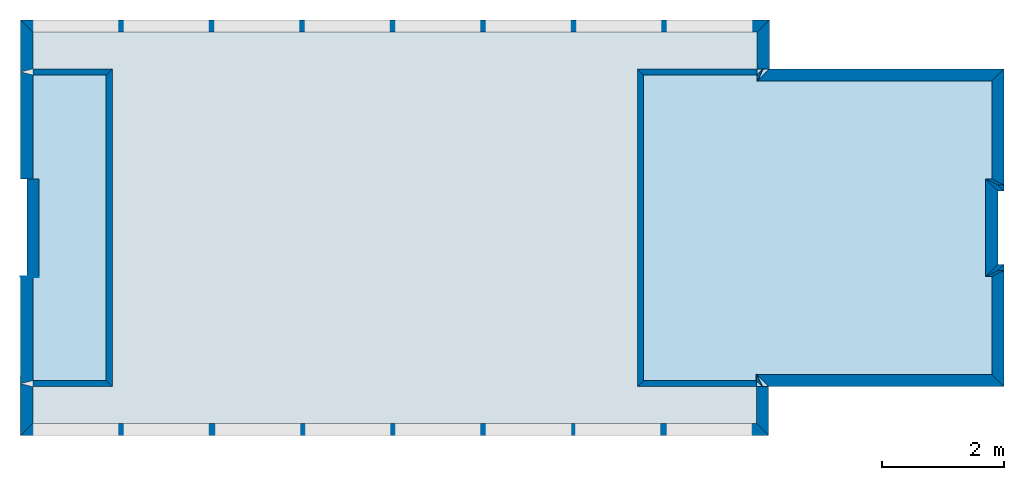
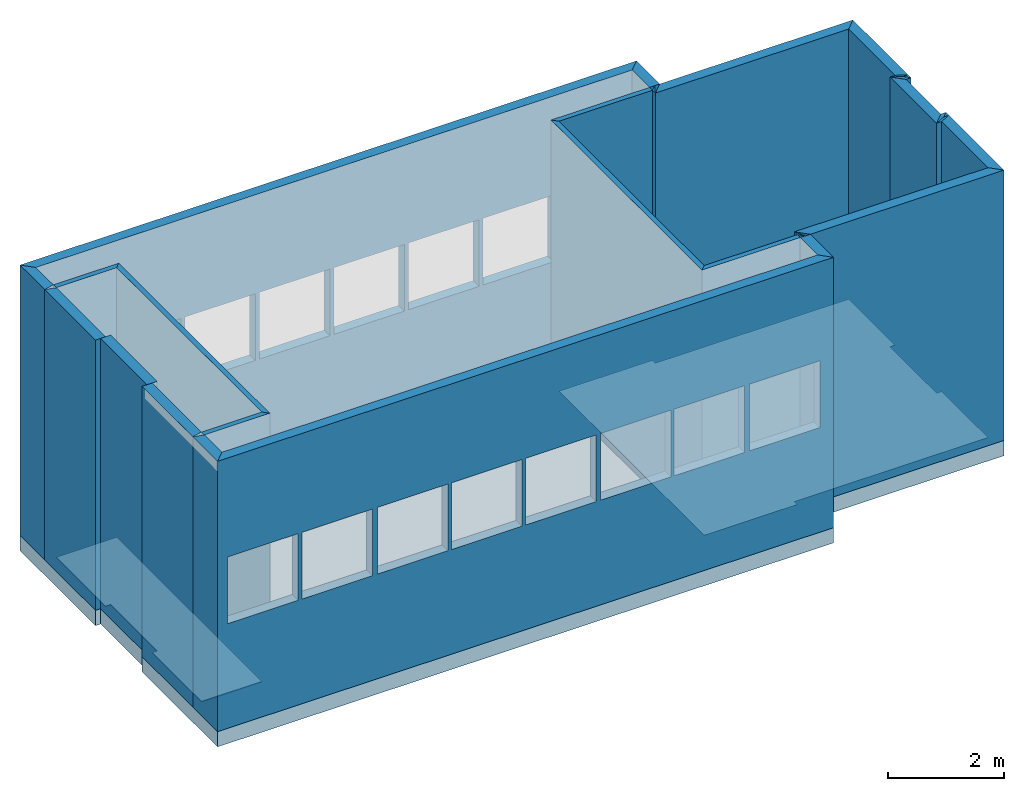
# One storey, part 1 of 18: 27 walls, 4 slabs, 16 openings.
"""IFC2X3 building model written with IfcOpenShell, lengths in metres."""

from ifc_helpers import new_model, entity, si_unit, converted_unit, derived_unit, frame, origin_with_axes, place, context, project, spatial, polyline, outline, extrude, material, layer, layer_set, layer_usage, element, save


model = new_model("IFC2X3")

# Units and contexts
context_of_model_1 = context(None, 3, world=origin_with_axes())
context_of_model_2 = context(None, 3, world=origin_with_axes())
context_of_model_3 = context(None, 2, world=origin_with_axes())
context_of_model_4 = context(None, 3, world=origin_with_axes())
ifc_project = project(units=[si_unit("LENGTHUNIT", "METRE"), si_unit("AREAUNIT", "SQUARE_METRE"), si_unit("ELECTRICCURRENTUNIT", "AMPERE"), si_unit("ELECTRICVOLTAGEUNIT", "VOLT"), si_unit("ELECTRICRESISTANCEUNIT", "OHM"), si_unit("POWERUNIT", "WATT"), si_unit("MASSUNIT", "GRAM"), si_unit("SOLIDANGLEUNIT", "STERADIAN"), si_unit("THERMODYNAMICTEMPERATUREUNIT", "KELVIN"), si_unit("PRESSUREUNIT", "PASCAL"), si_unit("LUMINOUSFLUXUNIT", "LUMEN"), si_unit("ILLUMINANCEUNIT", "LUX"), si_unit("FREQUENCYUNIT", "HERTZ"), si_unit("VOLUMEUNIT", "CUBIC_METRE"), si_unit("TIMEUNIT", "SECOND"), derived_unit("VOLUMETRICFLOWRATEUNIT", [(si_unit("TIMEUNIT", "SECOND"), -1), (si_unit("VOLUMEUNIT", "CUBIC_METRE"), 1)]), derived_unit("THERMALTRANSMITTANCEUNIT", [(si_unit("AREAUNIT", "SQUARE_METRE"), -1), (si_unit("THERMODYNAMICTEMPERATUREUNIT", "KELVIN"), -1), (si_unit("POWERUNIT", "WATT"), 1)]), converted_unit("PLANEANGLEUNIT", "DEGREE", entity("IfcPlaneAngleMeasure", 57.29577951308232), si_unit("PLANEANGLEUNIT", "RADIAN"), dimensions=[0, 0, 0, 0, 0, 0, 0])], contexts=[context_of_model_1, context_of_model_2, context_of_model_3, context_of_model_4])

# Site, building, storey
site = spatial("IfcSite", under=ifc_project, CompositionType="ELEMENT")
building_placement = place(None, origin_with_axes())
building = spatial("IfcBuilding", under=site, at=building_placement, Name="Tower", CompositionType="ELEMENT")
storey_placement = place(building_placement, frame((0.0, 0.0, 103.0), z_axis=(0.0, 0.0, 1.0), x_axis=(1.0, 0.0, 0.0)))
storey = spatial("IfcBuildingStorey", under=building, at=storey_placement, Name="Level 6", CompositionType="ELEMENT", Elevation=103.0)

# Slabs
ifc_material_1 = material()
ifc_layer_1 = layer(ifc_material_1, 0.3199999928474426, ventilated=False)
ifc_layer_set_1 = layer_set([ifc_layer_1])
ifc_layer_usage_1 = layer_usage(ifc_layer_set_1, "AXIS2", "POSITIVE", 0.0)
slab_1_placement = place(storey_placement, frame((0.1000000014901161, 1.399999976158142, 0.0), z_axis=(0.0, 0.0, 1.0), x_axis=(1.0, 0.0, 0.0)))
element("IfcSlab", 1, at=slab_1_placement, inside=storey, material=ifc_layer_usage_1, PredefinedType="FLOOR", context=context_of_model_1, shape_type="SweptSolid", body=[
    extrude(outline(polyline([(0.0, 0.0), (2.000000119209291, 0.0), (2.000000123679635, 0.0999999120831443), (3.199999932944773, 0.09999991089263416), (3.199999928474423, -1.430511357369829e-07), (5.200000405311582, -1.430511517241935e-07), (5.20000010013112, 3.839895351231112), (6.000000290865981, 3.839895315468318), (6.000001792110543, 16.088835068047), (3.400000456966503, 16.08883518427611), (3.399999975659022, 15.98883575648072), (1.800000786282108, 15.98883392065762), (1.800000790752515, 16.08883525580167), (-0.7999992926939846, 16.08883537203072), (-0.7999998398231419, 3.849762572348113), (1.720977860892539e-07, 3.849762536585327), (0.0, 0.0)])), frame((0.0, 0.0, 0.0), z_axis=(0.0, 0.0, 1.0), x_axis=(-4.470348091700783e-08, 0.9999999999999991, 0.0)), (0.0, 0.0, -1.0), 0.3199999928474426),
])
slab_2_placement = place(storey_placement, frame((-3.939895868301392, 6.600000381469727, 0.0), z_axis=(0.0, 0.0, 1.0), x_axis=(1.0, 0.0, 0.0)))
element("IfcSlab", 2, at=slab_2_placement, inside=storey, material=ifc_layer_usage_1, PredefinedType="FLOOR", context=context_of_model_1, shape_type="SweptSolid", body=[
    extrude(outline(polyline([(0.0, 0.0), (0.5999999046326159, 0.0), (0.5999961499604943, 11.84893989562933), (-4.708346343258583e-06, 11.84893965721037), (-4.191772597306827e-06, 10.54893946647561), (-5.200004597083773, 10.54893740018077), (-5.200005113657518, 11.84893759091553), (-5.800005137499329, 11.8489373524969), (-5.800000433073572, 0.009864171345491014), (-5.200000409231761, 0.009864409764117486), (-5.20000106497745, 1.960102160771091), (-7.788755649789618e-07, 1.960104227065886), (0.0, 0.0)])), frame((0.0, 0.0, 0.0), z_axis=(0.0, 0.0, 1.0), x_axis=(3.973643616619371e-07, 0.999999999999921, 0.0)), (0.0, 0.0, 1.0), 0.009999999776482582),
])
slab_3_placement = place(storey_placement, frame((-0.1000000089406967, 1.600000023841858, 0.0), z_axis=(0.0, 0.0, 1.0), x_axis=(1.0, 0.0, 0.0)))
element("IfcSlab", 3, at=slab_3_placement, inside=storey, material=ifc_layer_usage_1, PredefinedType="FLOOR", context=context_of_model_1, shape_type="SweptSolid", body=[
    extrude(outline(polyline([(0.0, 0.0), (1.60000002384186, -1.323488980084844e-23), (1.600000028498468, 0.09999990463256826), (3.19999969471246, 0.09999991953374611), (3.199999690055844, -1.490115952851313e-07), (4.80000054836273, -1.490116341429366e-07), (4.80000025033464, 3.839895397424694), (4.900000631804367, 3.839895392768063), (4.900000718422233, 5.699999953620113), (-0.09999963920562997, 5.70000018645077), (-0.09999984457333197, 3.849762340076265), (1.792685258227271e-07, 3.849762335419651), (0.0, 0.0)])), frame((0.0, 0.0, 0.0), z_axis=(0.0, 0.0, 1.0), x_axis=(-4.65661280368845e-08, 0.999999999999999, 0.0)), (0.0, 0.0, 1.0), 0.009999999776482582),
])
slab_4_placement = place(storey_placement, frame((-15.7888355255127, 6.500000476837158, 0.0), z_axis=(0.0, 0.0, 1.0), x_axis=(1.0, 0.0, 0.0)))
element("IfcSlab", 4, at=slab_4_placement, inside=storey, material=ifc_layer_usage_1, PredefinedType="FLOOR", context=context_of_model_1, shape_type="SweptSolid", body=[
    extrude(outline(polyline([(0.0, 0.0), (1.700000762939453, 0.0), (1.700001239776611, 0.1000003814697266), (3.305324554443359, 0.09904003143310547), (3.30534553527832, -0.001138687133789063), (5.000000357627869, 0.0), (5.000000476837158, 1.199999809265137), (0.0, 1.199999809265137), (0.0, 0.0)])), frame((0.0, 0.0, 0.0), z_axis=(0.0, 0.0, 1.0), x_axis=(0.0, -1.0, 0.0)), (0.0, 0.0, 1.0), 0.01999999955296516),
])

# Walls
ifc_material_2 = material(Name="Layer-Yttervegg 20.0cm")
ifc_layer_2 = layer(ifc_material_2, 0.2000000029802322, ventilated=False)
ifc_layer_set_2 = layer_set([ifc_layer_2], Name="ML-Yttervegg 20.0cm - 0.200")
ifc_layer_usage_2 = layer_usage(ifc_layer_set_2, "AXIS2", "POSITIVE", 0.0)
wall_1_placement = place(storey_placement, frame((0.09999991208314896, 3.400000095367432, 0.0), z_axis=(0.0, 0.0, 1.0), x_axis=(-1.0, -8.742277657347586e-08, 0.0)))
element("IfcWallStandardCase", 5, at=wall_1_placement, inside=storey, material=ifc_layer_usage_2, Name="Yttervegg 20.0cm", context=context_of_model_1, shape_type="SweptSolid", body=[
    extrude(outline(polyline([(0.0, 0.0), (0.0999999120831444, 0.0), (0.2999999299645421, 0.2000000476837162), (0.1999999880790708, 0.2000000476837158), (0.0, 0.0)])), frame((0.0, 0.0, 0.0), z_axis=(0.0, 0.0, 1.0), x_axis=(0.9999999999999961, -8.742278149038443e-08, 0.0)), (0.0, 0.0, 1.0), 5.680000007152557),
])
wall_2_placement = place(storey_placement, frame((-5.245365386485901e-08, 4.599999904632568, 0.0), z_axis=(0.0, 0.0, 1.0), x_axis=(1.0, 0.0, 0.0)))
element("IfcWallStandardCase", 6, at=wall_2_placement, inside=storey, material=ifc_layer_usage_2, Name="Yttervegg 20.0cm", context=context_of_model_1, shape_type="SweptSolid", body=[
    extrude(outline(polyline([(0.0, 0.0), (0.10000005394377, 0.0), (-0.09999995648704285, 0.1999998092651367), (-0.2000000250323843, 0.1999998092651367), (0.0, 0.0)])), origin_with_axes(), (0.0, 0.0, 1.0), 5.680000007152557),
])
wall_3_placement = place(storey_placement, frame((-3.739895582199097, 6.599999904632568, 0.0), z_axis=(0.0, 0.0, 1.0), x_axis=(-4.371138828673793e-08, 1.0, 0.0)))
element("IfcWallStandardCase", 7, at=wall_3_placement, inside=storey, material=ifc_layer_usage_2, Name="Yttervegg 20.0cm", context=context_of_model_1, shape_type="SweptSolid", body=[
    extrude(outline(polyline([(0.0, 0.0), (0.8000001907348633, 0.0), (0.600000381469726, 0.2000000476837155), (4.768371582176146e-07, 0.2000002861022946), (0.0, 0.0)])), frame((0.0, 0.0, 0.0), z_axis=(0.0, 0.0, 1.0), x_axis=(0.999999999999999, -4.371138963349459e-08, 0.0)), (0.0, 0.0, 1.0), 5.680000007152557),
])

# Wall, openings
ifc_material_3 = material()
ifc_layer_3 = layer(ifc_material_3, 0.2, ventilated=False)
ifc_layer_set_3 = layer_set([ifc_layer_3])
ifc_layer_usage_3 = layer_usage(ifc_layer_set_3, "AXIS2", "POSITIVE", 0.0)
wall_4_placement = place(storey_placement, frame((-3.739895582199097, 7.400000095367432, 0.0), z_axis=(0.0, 0.0, 1.0), x_axis=(-1.0, 1.509958025280866e-07, 0.0)))
wall_4 = element("IfcWallStandardCase", 8, at=wall_4_placement, inside=storey, material=ifc_layer_usage_3, context=context_of_model_1, shape_type="SweptSolid", body=[
    extrude(outline(polyline([(0.0, 0.0), (12.24893975257877, -1.058791184067875e-22), (12.04893992774211, 0.1999997936936115), (0.2000000321121897, 0.1999998248366815), (0.0, 0.0)])), frame((0.0, 0.0, 0.0), z_axis=(0.0, 0.0, 1.0), x_axis=(0.9999999999999973, 7.313809583869059e-08, 0.0)), (0.0, 0.0, 1.0), 5.680000007152557),
])
opening_1_placement = place(wall_4_placement, frame((10.64894029458421, 0.2000004635360728, 2.2), z_axis=(0.0, 0.0, 1.0), x_axis=(1.0, 0.0, 0.0)))
element("IfcOpeningElement", 9, at=opening_1_placement, cuts=wall_4, context=context_of_model_1, shape_type="SweptSolid", body=[
    extrude(outline(polyline([(0.0, 0.0), (1.399999976158142, 0.0), (1.399999976158142, 1.39999961853027), (0.0, 1.39999961853027), (0.0, 0.0)])), frame((0.0, 0.0, 0.0), z_axis=(1.153203098282065e-07, 0.9999999999999933, 0.0), x_axis=(0.0, 0.0, 1.0)), (0.0, 1.153203098282065e-07, -0.9999999999999933), 0.2),
])
opening_2_placement = place(wall_4_placement, frame((9.167823046049076, 0.2000002398935905, 2.2), z_axis=(0.0, 0.0, 1.0), x_axis=(1.0, 0.0, 0.0)))
element("IfcOpeningElement", 10, at=opening_2_placement, cuts=wall_4, context=context_of_model_1, shape_type="SweptSolid", body=[
    extrude(outline(polyline([(0.0, 0.0), (1.399999976158142, 0.0), (1.399999976158142, 1.399999618530248), (0.0, 1.399999618530248), (0.0, 0.0)])), frame((0.0, 0.0, 0.0), z_axis=(1.153203104626217e-07, 0.9999999999999934, 0.0), x_axis=(0.0, 0.0, 1.0)), (0.0, 1.153203104626217e-07, -0.9999999999999933), 0.2),
])
opening_3_placement = place(wall_4_placement, frame((7.686705797513865, 0.2000004930882655, 2.2), z_axis=(0.0, 0.0, 1.0), x_axis=(1.0, 0.0, 0.0)))
element("IfcOpeningElement", 11, at=opening_3_placement, cuts=wall_4, context=context_of_model_1, shape_type="SweptSolid", body=[
    extrude(outline(polyline([(0.0, 0.0), (1.399999976158142, 0.0), (1.399999976158142, 1.399999618530224), (0.0, 1.399999618530224), (0.0, 0.0)])), frame((0.0, 0.0, 0.0), z_axis=(1.153203098282103e-07, 0.9999999999999933, 0.0), x_axis=(0.0, 0.0, 1.0)), (0.0, 1.153203098282103e-07, -0.9999999999999933), 0.2),
])
opening_4_placement = place(wall_4_placement, frame((6.20558759530441, 0.2000002694456393, 2.2), z_axis=(0.0, 0.0, 1.0), x_axis=(1.0, 0.0, 0.0)))
element("IfcOpeningElement", 12, at=opening_4_placement, cuts=wall_4, context=context_of_model_1, shape_type="SweptSolid", body=[
    extrude(outline(polyline([(0.0, 0.0), (1.399999976158142, 0.0), (1.399999976158142, 1.3999996185302), (0.0, 1.3999996185302), (0.0, 0.0)])), frame((0.0, 0.0, 0.0), z_axis=(1.153203098282124e-07, 0.9999999999999934, 0.0), x_axis=(0.0, 0.0, 1.0)), (0.0, 1.153203098282124e-07, -0.9999999999999933), 0.2),
])
opening_5_placement = place(wall_4_placement, frame((4.724470346769271, 0.200000045803157, 2.2), z_axis=(0.0, 0.0, 1.0), x_axis=(1.0, 0.0, 0.0)))
element("IfcOpeningElement", 13, at=opening_5_placement, cuts=wall_4, context=context_of_model_1, shape_type="SweptSolid", body=[
    extrude(outline(polyline([(0.0, 0.0), (1.399999976158142, 0.0), (1.399999976158142, 1.399999618530173), (0.0, 1.399999618530173), (0.0, 0.0)])), frame((0.0, 0.0, 0.0), z_axis=(1.153203098282146e-07, 0.9999999999999933, 0.0), x_axis=(0.0, 0.0, 1.0)), (0.0, 1.153203098282146e-07, -0.9999999999999933), 0.2),
])
opening_6_placement = place(wall_4_placement, frame((3.243353098234131, 0.1999998221606747, 2.2), z_axis=(0.0, 0.0, 1.0), x_axis=(1.0, 0.0, 0.0)))
element("IfcOpeningElement", 14, at=opening_6_placement, cuts=wall_4, context=context_of_model_1, shape_type="SweptSolid", body=[
    extrude(outline(polyline([(0.0, 0.0), (1.399999976158142, 0.0), (1.399999976158142, 1.399999618530151), (0.0, 1.399999618530151), (0.0, 0.0)])), frame((0.0, 0.0, 0.0), z_axis=(1.153203104626297e-07, 0.9999999999999933, 0.0), x_axis=(0.0, 0.0, 1.0)), (0.0, 1.153203104626297e-07, -0.9999999999999933), 0.2),
])
opening_7_placement = place(wall_4_placement, frame((1.762234896024604, 0.2000000753552058, 2.2), z_axis=(0.0, 0.0, 1.0), x_axis=(1.0, 0.0, 0.0)))
element("IfcOpeningElement", 15, at=opening_7_placement, cuts=wall_4, context=context_of_model_1, shape_type="SweptSolid", body=[
    extrude(outline(polyline([(0.0, 0.0), (1.399999976158142, 0.0), (1.399999976158142, 1.399999618530126), (0.0, 1.399999618530126), (0.0, 0.0)])), frame((0.0, 0.0, 0.0), z_axis=(1.153203098282184e-07, 0.9999999999999933, 0.0), x_axis=(0.0, 0.0, 1.0)), (0.0, 1.153203098282184e-07, -0.9999999999999933), 0.2),
])
opening_8_placement = place(wall_4_placement, frame((0.2783190902079702, 0.1999998512901531, 2.2), z_axis=(0.0, 0.0, 1.0), x_axis=(1.0, 0.0, 0.0)))
element("IfcOpeningElement", 16, at=opening_8_placement, cuts=wall_4, context=context_of_model_1, shape_type="SweptSolid", body=[
    extrude(outline(polyline([(0.0, 0.0), (1.399999976158142, 0.0), (1.399999976158142, 1.399999618530102), (0.0, 1.399999618530102), (0.0, 0.0)])), frame((0.0, 0.0, 0.0), z_axis=(1.153203098282204e-07, 0.9999999999999933, 0.0), x_axis=(0.0, 0.0, 1.0)), (0.0, 1.153203098282204e-07, -0.9999999999999933), 0.2),
])

# Walls
ifc_material_4 = material()
ifc_layer_4 = layer(ifc_material_4, 0.2, ventilated=False)
ifc_layer_set_4 = layer_set([ifc_layer_4])
ifc_layer_usage_4 = layer_usage(ifc_layer_set_4, "AXIS2", "POSITIVE", 0.0)
wall_5_placement = place(storey_placement, frame((-15.98883533477783, 7.400001049041748, 0.0), z_axis=(0.0, 0.0, 1.0), x_axis=(-4.371138828673793e-08, -1.0, 0.0)))
element("IfcWallStandardCase", 17, at=wall_5_placement, inside=storey, material=ifc_layer_usage_4, context=context_of_model_1, shape_type="SweptSolid", body=[
    extrude(outline(polyline([(0.0, 0.0), (0.8500008583068847, 0.0), (0.8000006675720213, 0.1999998092651369), (0.1999998092651368, 0.1999998092651379), (0.0, 0.0)])), frame((0.0, 0.0, 0.0), z_axis=(0.0, 0.0, 1.0), x_axis=(0.9999999999999991, 4.371139137835724e-08, 0.0)), (0.0, 0.0, 1.0), 5.680000007152557),
])
ifc_material_5 = material()
ifc_layer_5 = layer(ifc_material_5, 0.1, ventilated=False)
ifc_layer_set_5 = layer_set([ifc_layer_5])
ifc_layer_usage_5 = layer_usage(ifc_layer_set_5, "AXIS2", "POSITIVE", 0.0)
wall_6_placement = place(storey_placement, frame((-15.7888355255127, 6.500000476837158, 0.0), z_axis=(0.0, 0.0, 1.0), x_axis=(1.0, 0.0, 0.0)))
element("IfcWallStandardCase", 18, at=wall_6_placement, inside=storey, material=ifc_layer_usage_5, context=context_of_model_1, shape_type="SweptSolid", body=[
    extrude(outline(polyline([(0.0, 0.0), (1.199999809265137, 0.0), (1.300000190734863, 0.09999990463256836), (0.0, 0.09999990463256836), (0.0, 0.0)])), origin_with_axes(), (0.0, 0.0, 1.0), 5.680000007152557),
])
wall_7_placement = place(storey_placement, frame((-14.58883571624756, 6.500000476837158, 0.0), z_axis=(0.0, 0.0, 1.0), x_axis=(-4.371138828673793e-08, -1.0, 0.0)))
element("IfcWallStandardCase", 19, at=wall_7_placement, inside=storey, material=ifc_layer_usage_5, context=context_of_model_1, shape_type="SweptSolid", body=[
    extrude(outline(polyline([(0.0, 0.0), (5.000000476837157, 0.0), (5.100000500679015, 0.1000003814697265), (-0.09999990463256864, 0.1000003814697269), (0.0, 0.0)])), frame((0.0, 0.0, 0.0), z_axis=(0.0, 0.0, 1.0), x_axis=(0.9999999999999991, 4.371139015770818e-08, 0.0)), (0.0, 0.0, 1.0), 5.680000007152557),
])
wall_8_placement = place(storey_placement, frame((-14.58883571624756, 1.5, 0.0), z_axis=(0.0, 0.0, 1.0), x_axis=(-1.0, 1.509958025280866e-07, 0.0)))
element("IfcWallStandardCase", 20, at=wall_8_placement, inside=storey, material=ifc_layer_usage_5, context=context_of_model_1, shape_type="SweptSolid", body=[
    extrude(outline(polyline([(0.0, 0.0), (1.199999809265142, 0.0), (1.199999799331019, 0.100000143051147), (-0.1000003914038372, 0.1000000139077105), (0.0, 0.0)])), frame((0.0, 0.0, 0.0), z_axis=(0.0, 0.0, 1.0), x_axis=(0.9999999999999987, 5.165470854219175e-08, 0.0)), (0.0, 0.0, 1.0), 5.680000007152557),
])
ifc_material_6 = material()
ifc_layer_6 = layer(ifc_material_6, 0.2, ventilated=False)
ifc_layer_set_6 = layer_set([ifc_layer_6])
ifc_layer_usage_6 = layer_usage(ifc_layer_set_6, "AXIS2", "POSITIVE", 0.0)
wall_9_placement = place(storey_placement, frame((-15.98883533477783, 1.450000047683716, 0.0), z_axis=(0.0, 0.0, 1.0), x_axis=(-4.371138828673793e-08, -1.0, 0.0)))
element("IfcWallStandardCase", 21, at=wall_9_placement, inside=storey, material=ifc_layer_usage_6, context=context_of_model_1, shape_type="SweptSolid", body=[
    extrude(outline(polyline([(0.0, 0.0), (0.8500000834465025, 0.0), (0.6500000953674314, 0.1999998092651363), (0.05000007152557353, 0.1999998092651369), (0.0, 0.0)])), frame((0.0, 0.0, 0.0), z_axis=(0.0, 0.0, 1.0), x_axis=(0.9999999999999991, 4.371138942904995e-08, 0.0)), (0.0, 0.0, 1.0), 5.680000007152557),
])

# Wall, openings
ifc_material_7 = material()
ifc_layer_7 = layer(ifc_material_7, 0.2, ventilated=False)
ifc_layer_set_7 = layer_set([ifc_layer_7])
ifc_layer_usage_7 = layer_usage(ifc_layer_set_7, "AXIS2", "POSITIVE", 0.0)
wall_10_placement = place(storey_placement, frame((-15.98883533477783, 0.5999999642372131, 0.0), z_axis=(0.0, 0.0, 1.0), x_axis=(1.0, 0.0, 0.0)))
wall_10 = element("IfcWallStandardCase", 22, at=wall_10_placement, inside=storey, material=ifc_layer_usage_7, context=context_of_model_1, shape_type="SweptSolid", body=[
    extrude(outline(polyline([(0.0, 0.0), (12.23907279968262, 0.0), (12.03907299041748, 0.199999988079071), (0.1999998092651367, 0.199999988079071), (0.0, 0.0)])), origin_with_axes(), (0.0, 0.0, 1.0), 5.680000007152557),
])
opening_9_placement = place(wall_10_placement, frame((0.1999998092651367, 0.199999988079071, 2.2), z_axis=(0.0, 0.0, 1.0), x_axis=(1.0, 0.0, 0.0)))
element("IfcOpeningElement", 23, at=opening_9_placement, cuts=wall_10, context=context_of_model_1, shape_type="SweptSolid", body=[
    extrude(outline(polyline([(0.0, 0.0), (1.399999976158142, 0.0), (1.399999976158142, 1.399999618530103), (0.0, 1.399999618530103), (0.0, 0.0)])), frame((0.0, 0.0, 0.0), z_axis=(0.0, 1.0, 0.0), x_axis=(0.0, 0.0, 1.0)), (0.0, 0.0, -1.0), 0.2),
])
opening_10_placement = place(wall_10_placement, frame((1.679572105407715, 0.199999988079071, 2.2), z_axis=(0.0, 0.0, 1.0), x_axis=(1.0, 0.0, 0.0)))
element("IfcOpeningElement", 24, at=opening_10_placement, cuts=wall_10, context=context_of_model_1, shape_type="SweptSolid", body=[
    extrude(outline(polyline([(0.0, 0.0), (1.399999976158142, 0.0), (1.399999976158142, 1.399999618530103), (0.0, 1.399999618530103), (0.0, 0.0)])), frame((0.0, 0.0, 0.0), z_axis=(0.0, 1.0, 0.0), x_axis=(0.0, 0.0, 1.0)), (0.0, 0.0, -1.0), 0.2),
])
opening_11_placement = place(wall_10_placement, frame((3.175571441650391, 0.199999988079071, 2.2), z_axis=(0.0, 0.0, 1.0), x_axis=(1.0, 0.0, 0.0)))
element("IfcOpeningElement", 25, at=opening_11_placement, cuts=wall_10, context=context_of_model_1, shape_type="SweptSolid", body=[
    extrude(outline(polyline([(0.0, 0.0), (1.399999976158142, 0.0), (1.399999976158142, 1.399999618530103), (0.0, 1.399999618530103), (0.0, 0.0)])), frame((0.0, 0.0, 0.0), z_axis=(0.0, 1.0, 0.0), x_axis=(0.0, 0.0, 1.0)), (0.0, 0.0, -1.0), 0.2),
])
opening_12_placement = place(wall_10_placement, frame((4.649572372436523, 0.199999988079071, 2.2), z_axis=(0.0, 0.0, 1.0), x_axis=(1.0, 0.0, 0.0)))
element("IfcOpeningElement", 26, at=opening_12_placement, cuts=wall_10, context=context_of_model_1, shape_type="SweptSolid", body=[
    extrude(outline(polyline([(0.0, 0.0), (1.399999976158142, 0.0), (1.399999976158142, 1.399999618530103), (0.0, 1.399999618530103), (0.0, 0.0)])), frame((0.0, 0.0, 0.0), z_axis=(0.0, 1.0, 0.0), x_axis=(0.0, 0.0, 1.0)), (0.0, 0.0, -1.0), 0.2),
])
opening_13_placement = place(wall_10_placement, frame((6.123573303222656, 0.199999988079071, 2.2), z_axis=(0.0, 0.0, 1.0), x_axis=(1.0, 0.0, 0.0)))
element("IfcOpeningElement", 27, at=opening_13_placement, cuts=wall_10, context=context_of_model_1, shape_type="SweptSolid", body=[
    extrude(outline(polyline([(0.0, 0.0), (1.399999976158142, 0.0), (1.399999976158142, 1.399999618530103), (0.0, 1.399999618530103), (0.0, 0.0)])), frame((0.0, 0.0, 0.0), z_axis=(0.0, 1.0, 0.0), x_axis=(0.0, 0.0, 1.0)), (0.0, 0.0, -1.0), 0.2),
])
opening_14_placement = place(wall_10_placement, frame((7.608574867248535, 0.199999988079071, 2.2), z_axis=(0.0, 0.0, 1.0), x_axis=(1.0, 0.0, 0.0)))
element("IfcOpeningElement", 28, at=opening_14_placement, cuts=wall_10, context=context_of_model_1, shape_type="SweptSolid", body=[
    extrude(outline(polyline([(0.0, 0.0), (1.399999976158142, 0.0), (1.399999976158142, 1.399999618530103), (0.0, 1.399999618530103), (0.0, 0.0)])), frame((0.0, 0.0, 0.0), z_axis=(0.0, 1.0, 0.0), x_axis=(0.0, 0.0, 1.0)), (0.0, 0.0, -1.0), 0.2),
])
opening_15_placement = place(wall_10_placement, frame((9.071574211120605, 0.199999988079071, 2.2), z_axis=(0.0, 0.0, 1.0), x_axis=(1.0, 0.0, 0.0)))
element("IfcOpeningElement", 29, at=opening_15_placement, cuts=wall_10, context=context_of_model_1, shape_type="SweptSolid", body=[
    extrude(outline(polyline([(0.0, 0.0), (1.399999976158142, 0.0), (1.399999976158142, 1.399999618530103), (0.0, 1.399999618530103), (0.0, 0.0)])), frame((0.0, 0.0, 0.0), z_axis=(0.0, 1.0, 0.0), x_axis=(0.0, 0.0, 1.0)), (0.0, 0.0, -1.0), 0.2),
])
opening_16_placement = place(wall_10_placement, frame((10.56757545471191, 0.199999988079071, 2.2), z_axis=(0.0, 0.0, 1.0), x_axis=(1.0, 0.0, 0.0)))
element("IfcOpeningElement", 30, at=opening_16_placement, cuts=wall_10, context=context_of_model_1, shape_type="SweptSolid", body=[
    extrude(outline(polyline([(0.0, 0.0), (1.399999976158142, 0.0), (1.399999976158142, 1.399999618530103), (0.0, 1.399999618530103), (0.0, 0.0)])), frame((0.0, 0.0, 0.0), z_axis=(0.0, 1.0, 0.0), x_axis=(0.0, 0.0, 1.0)), (0.0, 0.0, -1.0), 0.2),
])

# Walls
wall_11_placement = place(storey_placement, frame((-3.749762535095215, 0.5999999642372131, 0.0), z_axis=(0.0, 0.0, 1.0), x_axis=(-4.371138828673793e-08, 1.0, 0.0)))
element("IfcWallStandardCase", 31, at=wall_11_placement, inside=storey, material=ifc_layer_usage_2, Name="Yttervegg 20.0cm", context=context_of_model_1, shape_type="SweptSolid", body=[
    extrude(outline(polyline([(0.0, 0.0), (0.8000000119209291, -6.617444900424221e-24), (0.800000011920929, 0.1999998092651365), (0.1999999880790711, 0.1999998092651364), (0.0, 0.0)])), frame((0.0, 0.0, 0.0), z_axis=(0.0, 0.0, 1.0), x_axis=(0.999999999999999, -4.371138996685581e-08, 0.0)), (0.0, 0.0, 1.0), 5.680000007152557),
])
wall_12_placement = place(storey_placement, frame((-3.949762344360352, 1.5, 0.0), z_axis=(0.0, 0.0, 1.0), x_axis=(-1.0, 1.509958025280866e-07, 0.0)))
element("IfcWallStandardCase", 32, at=wall_12_placement, inside=storey, material=ifc_layer_usage_5, context=context_of_model_1, shape_type="SweptSolid", body=[
    extrude(outline(polyline([(0.0, 0.0), (1.850237846374515, 0.0), (1.950237744564166, 0.1000000302847687), (-6.442918429059665e-09, 0.1000000238418577), (0.0, 0.0)])), frame((0.0, 0.0, 0.0), z_axis=(0.0, 0.0, 1.0), x_axis=(0.9999999999999962, 8.656662868464251e-08, 0.0)), (0.0, 0.0, 1.0), 5.680000007152557),
])
wall_13_placement = place(storey_placement, frame((-5.800000190734863, 1.50000011920929, 0.0), z_axis=(0.0, 0.0, 1.0), x_axis=(-4.371138828673793e-08, 1.0, 0.0)))
element("IfcWallStandardCase", 33, at=wall_13_placement, inside=storey, material=ifc_layer_usage_5, context=context_of_model_1, shape_type="SweptSolid", body=[
    extrude(outline(polyline([(0.0, 0.0), (5.000000357627869, 0.0), (5.100000262260437, 0.0999999046325687), (-0.1000000238418578, 0.09999990463256829), (0.0, 0.0)])), frame((0.0, 0.0, 0.0), z_axis=(0.0, 0.0, 1.0), x_axis=(0.9999999999999991, -4.371138995641915e-08, 0.0)), (0.0, 0.0, 1.0), 5.680000007152557),
])
wall_14_placement = place(storey_placement, frame((-5.800000190734863, 6.500000476837158, 0.0), z_axis=(0.0, 0.0, 1.0), x_axis=(1.0, 0.0, 0.0)))
element("IfcWallStandardCase", 34, at=wall_14_placement, inside=storey, material=ifc_layer_usage_5, context=context_of_model_1, shape_type="SweptSolid", body=[
    extrude(outline(polyline([(0.0, 0.0), (1.860104560852051, 0.0), (1.860104322433472, 0.09999990463256836), (-0.09999990463256836, 0.09999990463256836), (0.0, 0.0)])), origin_with_axes(), (0.0, 0.0, 1.0), 5.680000007152557),
])
wall_15_placement = place(storey_placement, frame((0.1000000014901161, 1.399999976158142, 0.0), z_axis=(0.0, 0.0, 1.0), x_axis=(-4.371138828673793e-08, 1.0, 0.0)))
element("IfcWallStandardCase", 35, at=wall_15_placement, inside=storey, material=ifc_layer_usage_2, Name="Yttervegg 20.0cm", context=context_of_model_1, shape_type="SweptSolid", body=[
    extrude(outline(polyline([(0.0, 0.0), (2.000000119209291, 0.0), (1.800000080466272, 0.2000000044703497), (0.2000000566244123, 0.2000000014901143), (0.0, 0.0)])), frame((0.0, 0.0, 0.0), z_axis=(0.0, 0.0, 1.0), x_axis=(1.0, 9.92090919679804e-10, 0.0)), (0.0, 0.0, 1.0), 5.680000007152557),
])
wall_16_placement = place(storey_placement, frame((0.09999991953372955, 3.299999952316284, 0.0), z_axis=(0.0, 0.0, 1.0), x_axis=(-1.0, -8.742277657347586e-08, 0.0)))
element("IfcWallStandardCase", 36, at=wall_16_placement, inside=storey, material=ifc_layer_usage_5, context=context_of_model_1, shape_type="SweptSolid", body=[
    extrude(outline(polyline([(0.0, 0.0), (0.09999991208314898, 0.0), (0.2999999076128005, 0.09999990463256865), (0.2000000029802322, 0.09999990463256886), (0.0, 0.0)])), frame((0.0, 0.0, 0.0), z_axis=(0.0, 0.0, 1.0), x_axis=(0.9999999999999961, -8.742278149038043e-08, 0.0)), (0.0, 0.0, 1.0), 5.680000007152557),
])
wall_17_placement = place(storey_placement, frame((4.579669976578771e-15, 3.400000095367432, 0.0), z_axis=(0.0, 0.0, 1.0), x_axis=(-4.371138828673793e-08, 1.0, 0.0)))
element("IfcWallStandardCase", 37, at=wall_17_placement, inside=storey, material=ifc_layer_usage_2, Name="Yttervegg 20.0cm", context=context_of_model_1, shape_type="SweptSolid", body=[
    extrude(outline(polyline([(0.0, 0.0), (1.199999809265139, 0.0), (1.399999627272554, 0.2000000162901147), (-0.200000038941438, 0.1999999968213553), (0.0, 0.0)])), frame((0.0, 0.0, 0.0), z_axis=(0.0, 0.0, 1.0), x_axis=(1.0, -1.01701678366724e-15, 0.0)), (0.0, 0.0, 1.0), 5.680000007152557),
])
wall_18_placement = place(storey_placement, frame((-7.450580596923828e-08, 4.699999809265137, 0.0), z_axis=(0.0, 0.0, 1.0), x_axis=(1.0, 0.0, 0.0)))
element("IfcWallStandardCase", 38, at=wall_18_placement, inside=storey, material=ifc_layer_usage_5, context=context_of_model_1, shape_type="SweptSolid", body=[
    extrude(outline(polyline([(0.0, 0.0), (0.1000000685453415, 0.0), (-0.09999993443489075, 0.09999990463256836), (-0.2000000029802322, 0.09999990463256836), (0.0, 0.0)])), origin_with_axes(), (0.0, 0.0, 1.0), 5.680000007152557),
])
wall_19_placement = place(storey_placement, frame((0.1000000014901161, 4.599999904632568, 0.0), z_axis=(0.0, 0.0, 1.0), x_axis=(-4.371138828673793e-08, 1.0, 0.0)))
element("IfcWallStandardCase", 39, at=wall_19_placement, inside=storey, material=ifc_layer_usage_2, Name="Yttervegg 20.0cm", context=context_of_model_1, shape_type="SweptSolid", body=[
    extrude(outline(polyline([(0.0, 0.0), (2.00000047683716, 0.0), (1.800000676512718, 0.2000000044703375), (0.1999998182058313, 0.2000000014901266), (0.0, 0.0)])), frame((0.0, 0.0, 0.0), z_axis=(0.0, 0.0, 1.0), x_axis=(1.0, 9.920829221486003e-10, 0.0)), (0.0, 0.0, 1.0), 5.680000007152557),
])
wall_20_placement = place(storey_placement, frame((0.09999991208314896, 6.600000381469727, 0.0), z_axis=(0.0, 0.0, 1.0), x_axis=(-1.0, -1.509958025280866e-07, 0.0)))
element("IfcWallStandardCase", 40, at=wall_20_placement, inside=storey, material=ifc_layer_usage_2, Name="Yttervegg 20.0cm", context=context_of_model_1, shape_type="SweptSolid", body=[
    extrude(outline(polyline([(0.0, 0.0), (3.839895494282275, 0.0), (4.039895566801911, 0.1999997844291838), (0.200000020365571, 0.1999997844291904), (0.0, 0.0)])), frame((0.0, 0.0, 0.0), z_axis=(0.0, 0.0, 1.0), x_axis=(0.9999999999999997, -2.681607627142525e-08, 0.0)), (0.0, 0.0, 1.0), 5.680000007152557),
])
wall_21_placement = place(storey_placement, frame((-3.839895725250244, 6.599999904632568, 0.0), z_axis=(0.0, 0.0, 1.0), x_axis=(-4.371138828673793e-08, 1.0, 0.0)))
element("IfcWallStandardCase", 41, at=wall_21_placement, inside=storey, material=ifc_layer_usage_5, context=context_of_model_1, shape_type="SweptSolid", body=[
    extrude(outline(polyline([(0.0, 0.0), (-3.371739842166629e-07, -3.371755919557258e-07), (0.1414208841930086, -1.387778780781446e-17), (0.2121316634626929, 0.07071111644688433), (0.0, 0.0)])), frame((0.0, 0.0, 0.0), z_axis=(0.0, 0.0, 1.0), x_axis=(-0.707105064396276, 0.707108497972651, 0.0)), (0.0, 0.0, 1.0), 5.680000007152557),
])
wall_22_placement = place(storey_placement, frame((-3.849762439727783, 1.399999976158142, 0.0), z_axis=(0.0, 0.0, 1.0), x_axis=(1.0, 0.0, 0.0)))
element("IfcWallStandardCase", 42, at=wall_22_placement, inside=storey, material=ifc_layer_usage_5, context=context_of_model_1, shape_type="SweptSolid", body=[
    extrude(outline(polyline([(0.0, 0.0), (0.0, 0.0), (0.2236067977500044, 0.0), (0.1341640360004059, 0.04472132756277154), (0.0, 0.0)])), frame((0.0, 0.0, 0.0), z_axis=(0.0, 0.0, 1.0), x_axis=(-0.4472131690037871, 0.8944274042478741, 0.0)), (0.0, 0.0, 1.0), 5.680000007152557),
])
wall_23_placement = place(storey_placement, frame((-3.749762535095215, 1.399999976158142, 0.0), z_axis=(0.0, 0.0, 1.0), x_axis=(1.0, 0.0, 0.0)))
element("IfcWallStandardCase", 43, at=wall_23_placement, inside=storey, material=ifc_layer_usage_2, Name="Yttervegg 20.0cm", context=context_of_model_1, shape_type="SweptSolid", body=[
    extrude(outline(polyline([(0.0, 0.0), (3.849762536585331, 0.0), (3.649762526154518, 0.2000000476837158), (-0.1999998092651367, 0.2000000476837158), (0.0, 0.0)])), origin_with_axes(), (0.0, 0.0, 1.0), 5.680000007152557),
])
wall_24_placement = place(storey_placement, frame((-15.98883533477783, 6.550000190734863, 0.0), z_axis=(0.0, 0.0, 1.0), x_axis=(-4.371138828673793e-08, -1.0, 0.0)))
element("IfcWallStandardCase", 44, at=wall_24_placement, inside=storey, material=ifc_layer_usage_2, Name="Yttervegg 20.0cm", context=context_of_model_1, shape_type="SweptSolid", body=[
    extrude(outline(polyline([(0.0, 0.0), (1.750000476837158, 0.0), (1.750000476837157, 0.1999998092651369), (0.04999971389770468, 0.1999998092651365), (0.0, 0.0)])), frame((0.0, 0.0, 0.0), z_axis=(0.0, 0.0, 1.0), x_axis=(0.9999999999999991, 4.371138957212315e-08, 0.0)), (0.0, 0.0, 1.0), 5.680000007152557),
])
wall_25_placement = place(storey_placement, frame((-15.88883590698242, 4.799999237060547, 0.0), z_axis=(0.0, 0.0, 1.0), x_axis=(1.148381556959066e-06, -1.0, 0.0)))
element("IfcWallStandardCase", 45, at=wall_25_placement, inside=storey, material=ifc_layer_usage_2, Name="Yttervegg 20.0cm", context=context_of_model_1, shape_type="SweptSolid", body=[
    extrude(outline(polyline([(0.0, 0.0), (1.599999189377968, 0.0), (1.60532355194039, 0.1990384992072016), (2.384196089756942e-07, 0.2000007629393097), (0.0, 0.0)])), frame((0.0, 0.0, 0.0), z_axis=(0.0, 0.0, 1.0), x_axis=(0.999999999999999, 4.371199396615053e-08, 0.0)), (0.0, 0.0, 1.0), 5.680000007152557),
])
ifc_material_8 = material(Name="Layer-Yttervegg 15.0cm")
ifc_layer_8 = layer(ifc_material_8, 0.1490441709756851, ventilated=False)
ifc_layer_set_8 = layer_set([ifc_layer_8], Name="ML-Yttervegg 15.0cm - 0.149")
ifc_layer_usage_8 = layer_usage(ifc_layer_set_8, "AXIS2", "POSITIVE", 0.0)
wall_26_placement = place(storey_placement, frame((-15.88883399963379, 3.200000047683716, 0.0), z_axis=(0.0, 0.0, 1.0), x_axis=(-1.0, -8.742277657347586e-08, 0.0)))
element("IfcWallStandardCase", 46, at=wall_26_placement, inside=storey, material=ifc_layer_usage_8, Name="Yttervegg 15.0cm", context=context_of_model_1, shape_type="SweptSolid", body=[
    extrude(outline(polyline([(0.0, 0.0), (0.1000013351440434, 0.0), (-0.098859786987306, 0.005345106124877761), (-0.1990385055541982, 0.005324125289916623), (0.0, 0.0)])), frame((0.0, 0.0, 0.0), z_axis=(0.0, 0.0, 1.0), x_axis=(0.9999999999999962, -8.742278086076025e-08, 0.0)), (0.0, 0.0, 1.0), 5.680000007152557),
])
ifc_material_9 = material(Name="Layer-Yttervegg 20.0cm")
ifc_layer_9 = layer(ifc_material_9, 0.1992644965648651, ventilated=False)
ifc_layer_set_9 = layer_set([ifc_layer_9], Name="ML-Yttervegg 20.0cm - 0.199")
ifc_layer_usage_9 = layer_usage(ifc_layer_set_9, "AXIS2", "POSITIVE", 0.0)
wall_27_placement = place(storey_placement, frame((-15.98883533477783, 3.200000047683716, 0.0), z_axis=(0.0, 0.0, 1.0), x_axis=(-4.371138828673793e-08, -1.0, 0.0)))
element("IfcWallStandardCase", 47, at=wall_27_placement, inside=storey, material=ifc_layer_usage_9, Name="Yttervegg 20.0cm", context=context_of_model_1, shape_type="SweptSolid", body=[
    extrude(outline(polyline([(0.0, 0.0), (1.75, 0.0), (1.699999928474426, 0.1999998092651369), (0.005345106124878006, 0.1988611221313482), (0.0, 0.0)])), frame((0.0, 0.0, 0.0), z_axis=(0.0, 0.0, 1.0), x_axis=(0.9999999999999991, 4.371139031686004e-08, 0.0)), (0.0, 0.0, 1.0), 5.680000007152557),
])

save(model, "model.ifc")
